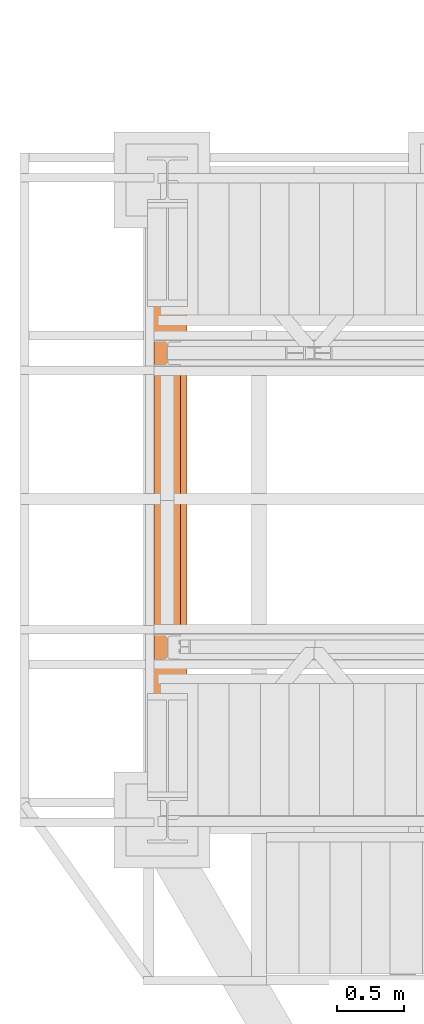
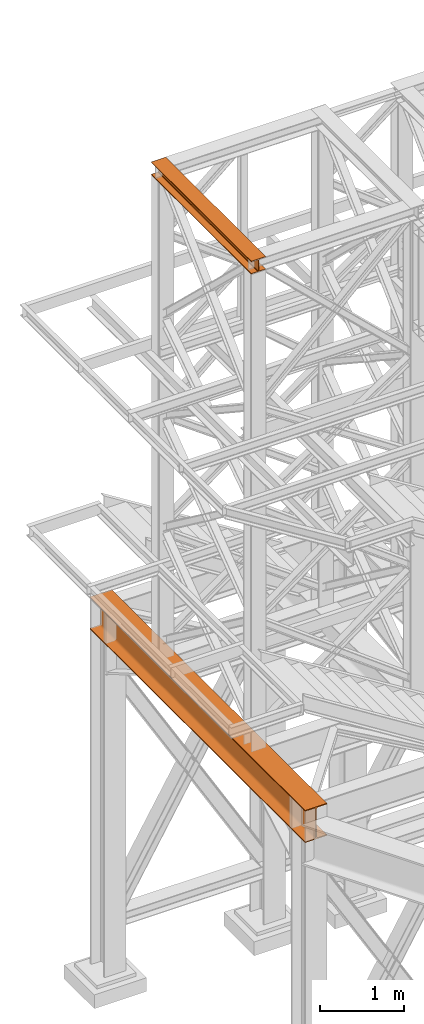
# One storey, part 94 of 208: 2 proxies.
"""IFC2X3 building model written with IfcOpenShell, lengths in millimetres."""

from ifc_helpers import new_model, entity, si_unit, converted_unit, frame, origin, origin_with_axes, place, context, subcontext, project, spatial, faceted_brep, element, save


model = new_model("IFC2X3")

# Units and contexts
model_context = context("Model", 3, precision=1e-05, world=origin())
plan_context = context("Plan", 3, precision=1e-05, world=origin())
body_context = subcontext(model_context, "Body", "Model", "MODEL_VIEW")
ifc_project = project(units=[si_unit("LENGTHUNIT", "METRE", prefix="MILLI"), converted_unit("PLANEANGLEUNIT", "DEGREE", entity("IfcPlaneAngleMeasure", 0.0174532925199433), si_unit("PLANEANGLEUNIT", "RADIAN"), dimensions=[0, 0, 0, 0, 0, 0, 0]), si_unit("AREAUNIT", "SQUARE_METRE"), si_unit("VOLUMEUNIT", "CUBIC_METRE")], contexts=[model_context, plan_context])

# Building, storey
building_placement = place(None, origin())
building = spatial("IfcBuilding", under=ifc_project, at=building_placement, CompositionType="COMPLEX")
storey_placement = place(building_placement, origin_with_axes())
storey = spatial("IfcBuildingStorey", under=building, at=storey_placement, Name="Geschoss", CompositionType="ELEMENT")

# Proxies
proxy_1_placement = place(storey_placement, frame((-3458.907627937124, -17432.57439531565, 4812.990005364416), z_axis=(0.0, 0.0, 1.0), x_axis=(1.0, 0.0, 0.0)))
element("IfcBuildingElementProxy", 1, at=proxy_1_placement, inside=storey, context=body_context, shape_type="Brep", body=[
    faceted_brep([(300.0100000000002, 0.00999999999839929, 472.0100000000002), (300.0100000000002, 5140.010003576275, 472.0100000000002), (300.0100000000002, 5140.010003576275, 458.0100000000002), (300.0100000000002, 0.00999999999839929, 458.0100000000002), (300.0100000000002, 0.00999999999839929, 458.0100000000002), (300.0100000000002, 5140.010003576275, 458.0100000000002), (182.2600000000002, 5140.010003576275, 458.0100000000002), (182.2600000000002, 0.00999999999839929, 458.0100000000002), (182.2600000000002, 0.00999999999839929, 458.0100000000002), (182.2600000000002, 5140.010003576275, 458.0100000000002), (173.9165694541389, 5140.010003576275, 456.6884339422595), (173.9165694541389, 0.00999999999839929, 456.6884339422595), (173.9165694541389, 0.00999999999839929, 456.6884339422595), (173.9165694541389, 5140.010003576275, 456.6884339422595), (166.3898249342001, 5140.010003576275, 452.8534254634024), (166.3898249342001, 0.00999999999839929, 452.8534254634024), (166.3898249342001, 0.00999999999839929, 452.8534254634024), (166.3898249342001, 5140.010003576275, 452.8534254634024), (160.416574536599, 5140.010003576275, 446.8801750658013), (160.416574536599, 0.00999999999839929, 446.8801750658013), (160.416574536599, 0.00999999999839929, 446.8801750658013), (160.416574536599, 5140.010003576275, 446.8801750658013), (156.5815660577409, 5140.010003576275, 439.3534305458607), (156.5815660577409, 0.00999999999839929, 439.3534305458607), (156.5815660577409, 0.00999999999839929, 439.3534305458607), (156.5815660577409, 5140.010003576275, 439.3534305458607), (155.2600000000002, 5140.010003576275, 431.0100000000002), (155.2600000000002, 0.00999999999839929, 431.0100000000002), (155.2600000000002, 0.00999999999839929, 431.0100000000002), (155.2600000000002, 5140.010003576275, 431.0100000000002), (155.2600000000002, 5140.010003576275, 41.01000000000022), (155.2600000000002, 0.00999999999839929, 41.01000000000022), (155.2600000000002, 0.00999999999839929, 41.01000000000022), (155.2600000000002, 5140.010003576275, 41.01000000000022), (156.5815660577409, 5140.010003576275, 32.66656945413979), (156.5815660577409, 0.00999999999839929, 32.66656945413979), (156.5815660577409, 0.00999999999839929, 32.66656945413979), (156.5815660577409, 5140.010003576275, 32.66656945413979), (160.416574536599, 5140.010003576275, 25.13982493419826), (160.416574536599, 0.00999999999839929, 25.13982493419826), (160.416574536599, 0.00999999999839929, 25.13982493419826), (160.416574536599, 5140.010003576275, 25.13982493419826), (166.3898249342001, 5140.010003576275, 19.16657453659809), (166.3898249342001, 0.00999999999839929, 19.16657453659809), (166.3898249342001, 0.00999999999839929, 19.16657453659809), (166.3898249342001, 5140.010003576275, 19.16657453659809), (173.9165694541389, 5140.010003576275, 15.33156605774093), (173.9165694541389, 0.00999999999839929, 15.33156605774093), (173.9165694541389, 0.00999999999839929, 15.33156605774093), (173.9165694541389, 5140.010003576275, 15.33156605774093), (182.2600000000002, 5140.010003576275, 14.01000000000022), (182.2600000000002, 0.00999999999839929, 14.01000000000022), (182.2600000000002, 0.00999999999839929, 14.01000000000022), (182.2600000000002, 5140.010003576275, 14.01000000000022), (300.0100000000002, 5140.010003576275, 14.01000000000022), (300.0100000000002, 0.00999999999839929, 14.01000000000022), (300.0100000000002, 0.00999999999839929, 14.01000000000022), (300.0100000000002, 5140.010003576275, 14.01000000000022), (300.0100000000002, 5140.010003576275, 0.01000000000021828), (300.0100000000002, 0.00999999999839929, 0.01000000000021828), (300.0100000000002, 0.00999999999839929, 0.01000000000021828), (300.0100000000002, 5140.010003576275, 0.01000000000021828), (0.01000000000021828, 5140.010003576275, 0.01000000000021828), (0.01000000000021828, 0.00999999999839929, 0.01000000000021828), (0.01000000000021828, 0.00999999999839929, 0.01000000000021828), (0.01000000000021828, 5140.010003576275, 0.01000000000021828), (0.01000000000021828, 5140.010003576275, 14.01000000000022), (0.01000000000021828, 0.00999999999839929, 14.01000000000022), (0.01000000000021828, 0.00999999999839929, 14.01000000000022), (0.01000000000021828, 5140.010003576275, 14.01000000000022), (117.7600000000002, 5140.010003576275, 14.01000000000022), (117.7600000000002, 0.00999999999839929, 14.01000000000022), (117.7600000000002, 0.00999999999839929, 14.01000000000022), (117.7600000000002, 5140.010003576275, 14.01000000000022), (126.1034305458616, 5140.010003576275, 15.33156605774093), (126.1034305458616, 0.00999999999839929, 15.33156605774093), (126.1034305458616, 0.00999999999839929, 15.33156605774093), (126.1034305458616, 5140.010003576275, 15.33156605774093), (133.6301750658004, 5140.010003576275, 19.16657453659809), (133.6301750658004, 0.00999999999839929, 19.16657453659809), (133.6301750658004, 0.00999999999839929, 19.16657453659809), (133.6301750658004, 5140.010003576275, 19.16657453659809), (139.6034254634014, 5140.010003576275, 25.13982493419826), (139.6034254634014, 0.00999999999839929, 25.13982493419826), (139.6034254634014, 0.00999999999839929, 25.13982493419826), (139.6034254634014, 5140.010003576275, 25.13982493419826), (143.4384339422595, 5140.010003576275, 32.66656945413979), (143.4384339422595, 0.00999999999839929, 32.66656945413979), (143.4384339422595, 0.00999999999839929, 32.66656945413979), (143.4384339422595, 5140.010003576275, 32.66656945413979), (144.7600000000002, 5140.010003576275, 41.01000000000022), (144.7600000000002, 0.00999999999839929, 41.01000000000022), (144.7600000000002, 0.00999999999839929, 41.01000000000022), (144.7600000000002, 5140.010003576275, 41.01000000000022), (144.7600000000002, 5140.010003576275, 431.0100000000002), (144.7600000000002, 0.00999999999839929, 431.0100000000002), (144.7600000000002, 0.00999999999839929, 431.0100000000002), (144.7600000000002, 5140.010003576275, 431.0100000000002), (143.4384339422595, 5140.010003576275, 439.3534305458607), (143.4384339422595, 0.00999999999839929, 439.3534305458607), (143.4384339422595, 0.00999999999839929, 439.3534305458607), (143.4384339422595, 5140.010003576275, 439.3534305458607), (139.6034254634014, 5140.010003576275, 446.8801750658013), (139.6034254634014, 0.00999999999839929, 446.8801750658013), (139.6034254634014, 0.00999999999839929, 446.8801750658013), (139.6034254634014, 5140.010003576275, 446.8801750658013), (133.6301750658004, 5140.010003576275, 452.8534254634024), (133.6301750658004, 0.00999999999839929, 452.8534254634024), (133.6301750658004, 0.00999999999839929, 452.8534254634024), (133.6301750658004, 5140.010003576275, 452.8534254634024), (126.1034305458616, 5140.010003576275, 456.6884339422595), (126.1034305458616, 0.00999999999839929, 456.6884339422595), (126.1034305458616, 0.00999999999839929, 456.6884339422595), (126.1034305458616, 5140.010003576275, 456.6884339422595), (117.7600000000002, 5140.010003576275, 458.0100000000002), (117.7600000000002, 0.00999999999839929, 458.0100000000002), (117.7600000000002, 0.00999999999839929, 458.0100000000002), (117.7600000000002, 5140.010003576275, 458.0100000000002), (0.01000000000021828, 5140.010003576275, 458.0100000000002), (0.01000000000021828, 0.00999999999839929, 458.0100000000002), (0.01000000000021828, 0.00999999999839929, 458.0100000000002), (0.01000000000021828, 5140.010003576275, 458.0100000000002), (0.01000000000021828, 5140.010003576275, 472.0100000000002), (0.01000000000021828, 0.00999999999839929, 472.0100000000002), (0.01000000000021828, 0.00999999999839929, 472.0100000000002), (0.01000000000021828, 5140.010003576275, 472.0100000000002), (300.0100000000002, 5140.010003576275, 472.0100000000002), (300.0100000000002, 0.00999999999839929, 472.0100000000002), (300.0100000000002, 0.00999999999839929, 472.0100000000002), (300.0100000000002, 0.00999999999839929, 458.0100000000002), (182.2600000000002, 0.00999999999839929, 458.0100000000002), (173.9165694541389, 0.00999999999839929, 456.6884339422595), (166.3898249342001, 0.00999999999839929, 452.8534254634024), (160.416574536599, 0.00999999999839929, 446.8801750658013), (156.5815660577409, 0.00999999999839929, 439.3534305458607), (155.2600000000002, 0.00999999999839929, 431.0100000000002), (155.2600000000002, 0.00999999999839929, 41.01000000000022), (156.5815660577409, 0.00999999999839929, 32.66656945413979), (160.416574536599, 0.00999999999839929, 25.13982493419826), (166.3898249342001, 0.00999999999839929, 19.16657453659809), (173.9165694541389, 0.00999999999839929, 15.33156605774093), (182.2600000000002, 0.00999999999839929, 14.01000000000022), (300.0100000000002, 0.00999999999839929, 14.01000000000022), (300.0100000000002, 0.00999999999839929, 0.01000000000021828), (0.01000000000021828, 0.00999999999839929, 0.01000000000021828), (0.01000000000021828, 0.00999999999839929, 14.01000000000022), (117.7600000000002, 0.00999999999839929, 14.01000000000022), (126.1034305458616, 0.00999999999839929, 15.33156605774093), (133.6301750658004, 0.00999999999839929, 19.16657453659809), (139.6034254634014, 0.00999999999839929, 25.13982493419826), (143.4384339422595, 0.00999999999839929, 32.66656945413979), (144.7600000000002, 0.00999999999839929, 41.01000000000022), (144.7600000000002, 0.00999999999839929, 431.0100000000002), (143.4384339422595, 0.00999999999839929, 439.3534305458607), (139.6034254634014, 0.00999999999839929, 446.8801750658013), (133.6301750658004, 0.00999999999839929, 452.8534254634024), (126.1034305458616, 0.00999999999839929, 456.6884339422595), (117.7600000000002, 0.00999999999839929, 458.0100000000002), (0.01000000000021828, 0.00999999999839929, 458.0100000000002), (0.01000000000021828, 0.00999999999839929, 472.0100000000002), (300.0100000000002, 5140.010003576275, 472.0100000000002), (0.01000000000021828, 5140.010003576275, 472.0100000000002), (0.01000000000021828, 5140.010003576275, 458.0100000000002), (117.7600000000002, 5140.010003576275, 458.0100000000002), (126.1034305458616, 5140.010003576275, 456.6884339422595), (133.6301750658004, 5140.010003576275, 452.8534254634024), (139.6034254634014, 5140.010003576275, 446.8801750658013), (143.4384339422595, 5140.010003576275, 439.3534305458607), (144.7600000000002, 5140.010003576275, 431.0100000000002), (144.7600000000002, 5140.010003576275, 41.01000000000022), (143.4384339422595, 5140.010003576275, 32.66656945413979), (139.6034254634014, 5140.010003576275, 25.13982493419826), (133.6301750658004, 5140.010003576275, 19.16657453659809), (126.1034305458616, 5140.010003576275, 15.33156605774093), (117.7600000000002, 5140.010003576275, 14.01000000000022), (0.01000000000021828, 5140.010003576275, 14.01000000000022), (0.01000000000021828, 5140.010003576275, 0.01000000000021828), (300.0100000000002, 5140.010003576275, 0.01000000000021828), (300.0100000000002, 5140.010003576275, 14.01000000000022), (182.2600000000002, 5140.010003576275, 14.01000000000022), (173.9165694541389, 5140.010003576275, 15.33156605774093), (166.3898249342001, 5140.010003576275, 19.16657453659809), (160.416574536599, 5140.010003576275, 25.13982493419826), (156.5815660577409, 5140.010003576275, 32.66656945413979), (155.2600000000002, 5140.010003576275, 41.01000000000022), (155.2600000000002, 5140.010003576275, 431.0100000000002), (156.5815660577409, 5140.010003576275, 439.3534305458607), (160.416574536599, 5140.010003576275, 446.8801750658013), (166.3898249342001, 5140.010003576275, 452.8534254634024), (173.9165694541389, 5140.010003576275, 456.6884339422595), (182.2600000000002, 5140.010003576275, 458.0100000000002), (300.0100000000002, 5140.010003576275, 458.0100000000002)], [[[0, 1, 2, 3]], [[4, 5, 6, 7]], [[8, 9, 10, 11]], [[12, 13, 14, 15]], [[16, 17, 18, 19]], [[20, 21, 22, 23]], [[24, 25, 26, 27]], [[28, 29, 30, 31]], [[32, 33, 34, 35]], [[36, 37, 38, 39]], [[40, 41, 42, 43]], [[44, 45, 46, 47]], [[48, 49, 50, 51]], [[52, 53, 54, 55]], [[56, 57, 58, 59]], [[60, 61, 62, 63]], [[64, 65, 66, 67]], [[68, 69, 70, 71]], [[72, 73, 74, 75]], [[76, 77, 78, 79]], [[80, 81, 82, 83]], [[84, 85, 86, 87]], [[88, 89, 90, 91]], [[92, 93, 94, 95]], [[96, 97, 98, 99]], [[100, 101, 102, 103]], [[104, 105, 106, 107]], [[108, 109, 110, 111]], [[112, 113, 114, 115]], [[116, 117, 118, 119]], [[120, 121, 122, 123]], [[124, 125, 126, 127]], [[128, 129, 130, 131, 132, 133, 134, 135, 136, 137, 138, 139, 140, 141, 142, 143, 144, 145, 146, 147, 148, 149, 150, 151, 152, 153, 154, 155, 156, 157, 158, 159]], [[160, 161, 162, 163, 164, 165, 166, 167, 168, 169, 170, 171, 172, 173, 174, 175, 176, 177, 178, 179, 180, 181, 182, 183, 184, 185, 186, 187, 188, 189, 190, 191]]], orient=[[False], [False], [False], [False], [False], [False], [False], [False], [False], [False], [False], [False], [False], [False], [False], [False], [False], [False], [False], [False], [False], [False], [False], [False], [False], [False], [False], [False], [False], [False], [False], [False], [False], [False]]),
])
proxy_2_placement = place(storey_placement, frame((-3406.745032961453, -16057.57439657637, 12249.99005869381), z_axis=(0.0, 0.0, 1.0), x_axis=(1.0, 0.0, 0.0)))
element("IfcBuildingElementProxy", 2, at=proxy_2_placement, inside=storey, context=body_context, shape_type="Brep", body=[
    faceted_brep([(0.01000000000021828, 2390.010012516976, 0.01000000000021828), (200.0100029802325, 2390.010012516976, 0.01000000000021828), (200.0100029802325, 2390.010012516976, 10.00999791383765), (121.2600035762789, 2390.010012516976, 10.01000536441825), (111.9441915473344, 2390.010012516976, 11.87455041170142), (105.1245498640838, 2390.010012516976, 18.69419349193595), (103.2600015571716, 2390.010012516976, 28.01000458955787), (103.2600015571716, 2390.010012516976, 162.0100153779986), (105.1245498640838, 2390.010012516976, 171.3258264756205), (111.9441915473344, 2390.010012516976, 178.145469555855), (121.2600035762789, 2390.010012516976, 180.0100146031382), (200.0100029802325, 2390.010012516976, 180.0100146031382), (200.0100029802325, 2390.010012516976, 190.0100125169756), (0.01000000000021828, 2390.010012516976, 190.0100125169756), (0.01000000000021828, 2390.010012516976, 180.0100146031382), (78.75999940395377, 2390.010012516976, 180.0100146031382), (88.07581143289826, 2390.010012516976, 178.145469555855), (94.89545311614893, 2390.010012516976, 171.3258264756205), (96.76000142306111, 2390.010012516976, 162.0100153779986), (96.76000142306111, 2390.010012516976, 28.01000458955787), (94.89545311614893, 2390.010012516976, 18.69419349193595), (88.07581143289826, 2390.010012516976, 11.87455041170142), (78.75999940395377, 2390.010012516976, 10.01000536441825), (0.01000000000021828, 2390.010012516976, 10.00999791383765), (200.0100029802325, 2390.010012516976, 0.01000000000021828), (0.01000000000021828, 2390.010012516976, 0.01000000000021828), (0.01000000000021828, 0.00999999999839929, 0.01000000000021828), (200.0100029802325, 0.00999999999839929, 0.01000000000021828), (200.0100029802325, 2390.010012516976, 10.00999791383765), (200.0100029802325, 2390.010012516976, 0.01000000000021828), (200.0100029802325, 0.00999999999839929, 0.01000000000021828), (200.0100029802325, 0.00999999999839929, 10.00999791383765), (121.2600035762789, 2390.010012516976, 10.01000536441825), (200.0100029802325, 2390.010012516976, 10.00999791383765), (200.0100029802325, 0.00999999999839929, 10.00999791383765), (121.2600035762789, 0.00999999999839929, 10.01000536441825), (111.9441915473344, 2390.010012516976, 11.87455041170142), (121.2600035762789, 2390.010012516976, 10.01000536441825), (121.2600035762789, 0.00999999999839929, 10.01000536441825), (111.9441915473344, 0.00999999999839929, 11.87455041170142), (105.1245498640838, 2390.010012516976, 18.69419349193595), (111.9441915473344, 2390.010012516976, 11.87455041170142), (111.9441915473344, 0.00999999999839929, 11.87455041170142), (105.1245498640838, 0.00999999999839929, 18.69419349193595), (103.2600015571716, 2390.010012516976, 28.01000458955787), (105.1245498640838, 2390.010012516976, 18.69419349193595), (105.1245498640838, 0.00999999999839929, 18.69419349193595), (103.2600015571716, 0.00999999999839929, 28.01000458955787), (103.2600015571716, 2390.010012516976, 162.0100153779986), (103.2600015571716, 2390.010012516976, 28.01000458955787), (103.2600015571716, 0.00999999999839929, 28.01000458955787), (103.2600015571716, 0.00999999999839929, 162.0100153779986), (105.1245498640838, 2390.010012516976, 171.3258264756205), (103.2600015571716, 2390.010012516976, 162.0100153779986), (103.2600015571716, 0.00999999999839929, 162.0100153779986), (105.1245498640838, 0.00999999999839929, 171.3258264756205), (111.9441915473344, 2390.010012516976, 178.145469555855), (105.1245498640838, 2390.010012516976, 171.3258264756205), (105.1245498640838, 0.00999999999839929, 171.3258264756205), (111.9441915473344, 0.00999999999839929, 178.145469555855), (121.2600035762789, 2390.010012516976, 180.0100146031382), (111.9441915473344, 2390.010012516976, 178.145469555855), (111.9441915473344, 0.00999999999839929, 178.145469555855), (121.2600035762789, 0.00999999999839929, 180.0100146031382), (200.0100029802325, 2390.010012516976, 180.0100146031382), (121.2600035762789, 2390.010012516976, 180.0100146031382), (121.2600035762789, 0.00999999999839929, 180.0100146031382), (200.0100029802325, 0.00999999999839929, 180.0100146031382), (200.0100029802325, 2390.010012516976, 190.0100125169756), (200.0100029802325, 2390.010012516976, 180.0100146031382), (200.0100029802325, 0.00999999999839929, 180.0100146031382), (200.0100029802325, 0.00999999999839929, 190.0100125169756), (0.01000000000021828, 2390.010012516976, 190.0100125169756), (200.0100029802325, 2390.010012516976, 190.0100125169756), (200.0100029802325, 0.00999999999839929, 190.0100125169756), (0.01000000000021828, 0.00999999999839929, 190.0100125169756), (0.01000000000021828, 2390.010012516976, 180.0100146031382), (0.01000000000021828, 2390.010012516976, 190.0100125169756), (0.01000000000021828, 0.00999999999839929, 190.0100125169756), (0.01000000000021828, 0.00999999999839929, 180.0100146031382), (78.75999940395377, 2390.010012516976, 180.0100146031382), (0.01000000000021828, 2390.010012516976, 180.0100146031382), (0.01000000000021828, 0.00999999999839929, 180.0100146031382), (78.75999940395377, 0.00999999999839929, 180.0100146031382), (88.07581143289826, 2390.010012516976, 178.145469555855), (78.75999940395377, 2390.010012516976, 180.0100146031382), (78.75999940395377, 0.00999999999839929, 180.0100146031382), (88.07581143289826, 0.00999999999839929, 178.145469555855), (94.89545311614893, 2390.010012516976, 171.3258264756205), (88.07581143289826, 2390.010012516976, 178.145469555855), (88.07581143289826, 0.00999999999839929, 178.145469555855), (94.89545311614893, 0.00999999999839929, 171.3258264756205), (96.76000142306111, 2390.010012516976, 162.0100153779986), (94.89545311614893, 2390.010012516976, 171.3258264756205), (94.89545311614893, 0.00999999999839929, 171.3258264756205), (96.76000142306111, 0.00999999999839929, 162.0100153779986), (96.76000142306111, 2390.010012516976, 28.01000458955787), (96.76000142306111, 2390.010012516976, 162.0100153779986), (96.76000142306111, 0.00999999999839929, 162.0100153779986), (96.76000142306111, 0.00999999999839929, 28.01000458955787), (94.89545311614893, 2390.010012516976, 18.69419349193595), (96.76000142306111, 2390.010012516976, 28.01000458955787), (96.76000142306111, 0.00999999999839929, 28.01000458955787), (94.89545311614893, 0.00999999999839929, 18.69419349193595), (88.07581143289826, 2390.010012516976, 11.87455041170142), (94.89545311614893, 2390.010012516976, 18.69419349193595), (94.89545311614893, 0.00999999999839929, 18.69419349193595), (88.07581143289826, 0.00999999999839929, 11.87455041170142), (78.75999940395377, 2390.010012516976, 10.01000536441825), (88.07581143289826, 2390.010012516976, 11.87455041170142), (88.07581143289826, 0.00999999999839929, 11.87455041170142), (78.75999940395377, 0.00999999999839929, 10.01000536441825), (0.01000000000021828, 2390.010012516976, 10.00999791383765), (78.75999940395377, 2390.010012516976, 10.01000536441825), (78.75999940395377, 0.00999999999839929, 10.01000536441825), (0.01000000000021828, 0.00999999999839929, 10.00999791383765), (0.01000000000021828, 2390.010012516976, 0.01000000000021828), (0.01000000000021828, 2390.010012516976, 10.00999791383765), (0.01000000000021828, 0.00999999999839929, 10.00999791383765), (0.01000000000021828, 0.00999999999839929, 0.01000000000021828), (0.01000000000021828, 0.00999999999839929, 0.01000000000021828), (0.01000000000021828, 0.00999999999839929, 10.00999791383765), (78.75999940395377, 0.00999999999839929, 10.01000536441825), (88.07581143289826, 0.00999999999839929, 11.87455041170142), (94.89545311614893, 0.00999999999839929, 18.69419349193595), (96.76000142306111, 0.00999999999839929, 28.01000458955787), (96.76000142306111, 0.00999999999839929, 162.0100153779986), (94.89545311614893, 0.00999999999839929, 171.3258264756205), (88.07581143289826, 0.00999999999839929, 178.145469555855), (78.75999940395377, 0.00999999999839929, 180.0100146031382), (0.01000000000021828, 0.00999999999839929, 180.0100146031382), (0.01000000000021828, 0.00999999999839929, 190.0100125169756), (200.0100029802325, 0.00999999999839929, 190.0100125169756), (200.0100029802325, 0.00999999999839929, 180.0100146031382), (121.2600035762789, 0.00999999999839929, 180.0100146031382), (111.9441915473344, 0.00999999999839929, 178.145469555855), (105.1245498640838, 0.00999999999839929, 171.3258264756205), (103.2600015571716, 0.00999999999839929, 162.0100153779986), (103.2600015571716, 0.00999999999839929, 28.01000458955787), (105.1245498640838, 0.00999999999839929, 18.69419349193595), (111.9441915473344, 0.00999999999839929, 11.87455041170142), (121.2600035762789, 0.00999999999839929, 10.01000536441825), (200.0100029802325, 0.00999999999839929, 10.00999791383765), (200.0100029802325, 0.00999999999839929, 0.01000000000021828)], [[[0, 1, 2, 3, 4, 5, 6, 7, 8, 9, 10, 11, 12, 13, 14, 15, 16, 17, 18, 19, 20, 21, 22, 23]], [[24, 25, 26, 27]], [[28, 29, 30, 31]], [[32, 33, 34, 35]], [[36, 37, 38, 39]], [[40, 41, 42, 43]], [[44, 45, 46, 47]], [[48, 49, 50, 51]], [[52, 53, 54, 55]], [[56, 57, 58, 59]], [[60, 61, 62, 63]], [[64, 65, 66, 67]], [[68, 69, 70, 71]], [[72, 73, 74, 75]], [[76, 77, 78, 79]], [[80, 81, 82, 83]], [[84, 85, 86, 87]], [[88, 89, 90, 91]], [[92, 93, 94, 95]], [[96, 97, 98, 99]], [[100, 101, 102, 103]], [[104, 105, 106, 107]], [[108, 109, 110, 111]], [[112, 113, 114, 115]], [[116, 117, 118, 119]], [[120, 121, 122, 123, 124, 125, 126, 127, 128, 129, 130, 131, 132, 133, 134, 135, 136, 137, 138, 139, 140, 141, 142, 143]]], orient=[[False], [False], [False], [False], [False], [False], [False], [False], [False], [False], [False], [False], [False], [False], [False], [False], [False], [False], [False], [False], [False], [False], [False], [False], [False], [False]]),
])

save(model, "model.ifc")
